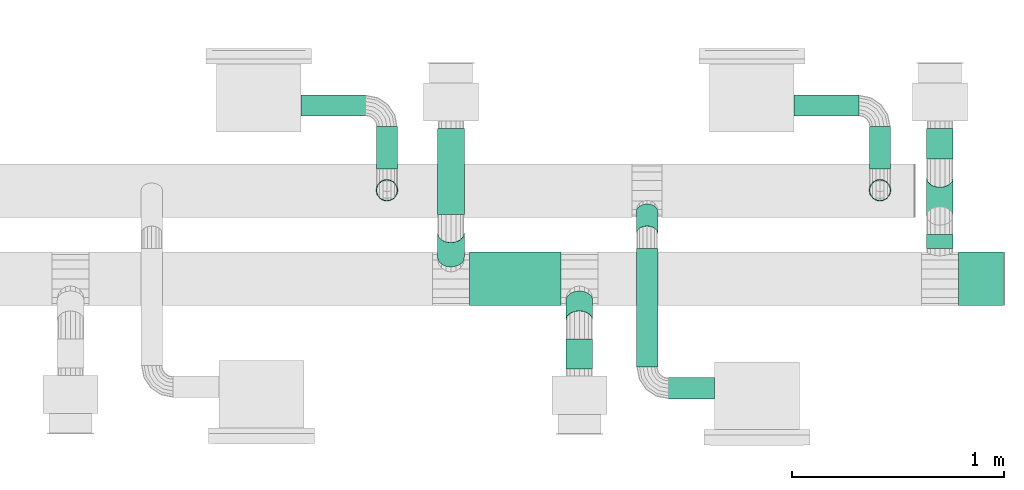
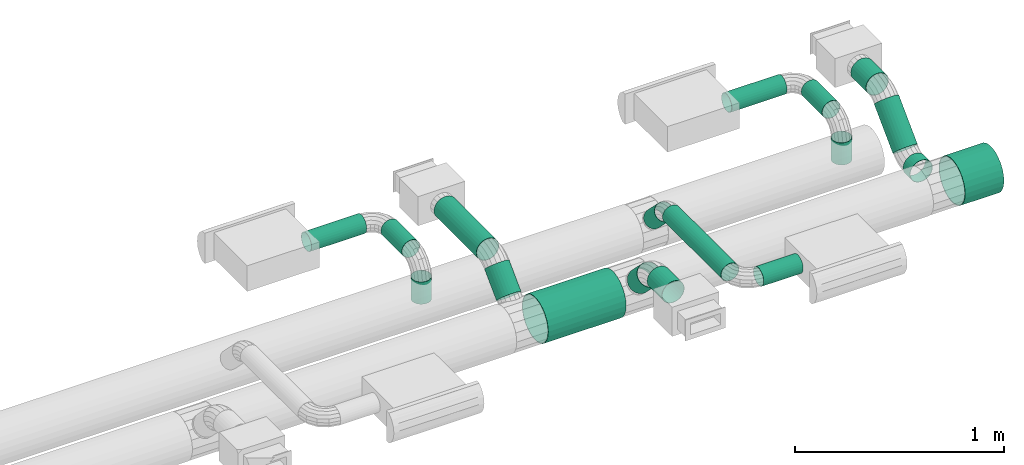
# One storey, part 3 of 11: 18 flow segments.
"""IFC2X3 building model written with IfcOpenShell, lengths in millimetres."""

from ifc_helpers import new_model, si_unit, derived_unit, frame, origin_with_axes, origin_2d_with_axis, place, context, project, spatial, hollow_circle, extrude, source, transform, mapped, type_object, element, save


model = new_model("IFC2X3")

# Units and contexts
context_of_model = context(None, 3, precision=1e-05, world=origin_with_axes())
ifc_project = project(units=[si_unit("LENGTHUNIT", "METRE", prefix="MILLI"), si_unit("AREAUNIT", "SQUARE_METRE"), si_unit("VOLUMEUNIT", "CUBIC_METRE"), si_unit("PLANEANGLEUNIT", "RADIAN"), si_unit("TIMEUNIT", "SECOND"), si_unit("POWERUNIT", "WATT"), si_unit("THERMODYNAMICTEMPERATUREUNIT", "DEGREE_CELSIUS"), derived_unit("VOLUMETRICFLOWRATEUNIT", [(si_unit("VOLUMEUNIT", "CUBIC_METRE"), 1), (si_unit("TIMEUNIT", "SECOND"), -1)])], contexts=[context_of_model])

# Site, building, storey
site_placement = place(None, origin_with_axes())
site = spatial("IfcSite", under=ifc_project, at=site_placement, CompositionType="ELEMENT")
building_placement = place(site_placement, origin_with_axes())
building = spatial("IfcBuilding", under=site, at=building_placement, CompositionType="ELEMENT")
storey_placement = place(building_placement, frame((0.0, 0.0, 3800.0), z_axis=(0.0, 0.0, 1.0), x_axis=(1.0, 0.0, 0.0)))
storey = spatial("IfcBuildingStorey", under=building, at=storey_placement, Name="First floor", CompositionType="ELEMENT")

# Flow segments
duct_segment_type_1 = type_object("IfcDuctSegmentType", PredefinedType="RIGIDSEGMENT")
shared_shape_1 = source(origin_with_axes(), context_of_model, "Body", "SweptSolid", [
    extrude(hollow_circle(Radius=63.0, WallThickness=2.0, at=origin_2d_with_axis()), frame((0.0, 0.0, 0.0), z_axis=(1.0, 0.0, 0.0), x_axis=(0.0, 1.0, 0.0)), (0.0, 0.0, 1.0), 306.0),
])
flow_segment_1_placement = place(storey_placement, frame((12260.89272, 4463.3661, 2566.12943), z_axis=(0.0, -0.707107, 0.707107), x_axis=(0.0, -0.707107, -0.707107)))
element("IfcFlowSegment", 1, at=flow_segment_1_placement, inside=storey, type_object=duct_segment_type_1, context=context_of_model, shape_type="MappedRepresentation", body=[
    mapped(shared_shape_1, transform((0.0, 0.0, 0.0), scale=0.529696, scale2=1.0, scale3=1.0, uniform=False)),
])
duct_segment_type_2 = type_object("IfcDuctSegmentType", PredefinedType="RIGIDSEGMENT")
shared_shape_2 = source(origin_with_axes(), context_of_model, "Body", "SweptSolid", [
    extrude(hollow_circle(Radius=63.0, WallThickness=2.0, at=origin_2d_with_axis()), frame((0.0, 0.0, 0.0), z_axis=(1.0, 0.0, 0.0), x_axis=(0.0, 1.0, 0.0)), (0.0, 0.0, 1.0), 306.0),
])
flow_segment_2_placement = place(storey_placement, frame((12260.89272, 4957.70026, 2602.74108), z_axis=(0.0, 0.0, 1.0), x_axis=(0.0, -1.0, 0.0)))
element("IfcFlowSegment", 2, at=flow_segment_2_placement, inside=storey, type_object=duct_segment_type_2, context=context_of_model, shape_type="MappedRepresentation", body=[
    mapped(shared_shape_2, transform((0.0, 0.0, 0.0), scale=1.328126, scale2=1.0, scale3=1.0, uniform=False)),
])
duct_segment_type_3 = type_object("IfcDuctSegmentType", PredefinedType="RIGIDSEGMENT")
shared_shape_3 = source(origin_with_axes(), context_of_model, "Body", "SweptSolid", [
    extrude(hollow_circle(Radius=63.0, WallThickness=2.0, at=origin_2d_with_axis()), frame((0.0, 0.0, 0.0), z_axis=(1.0, 0.0, 0.0), x_axis=(0.0, 1.0, 0.0)), (0.0, 0.0, 1.0), 306.0),
])
flow_segment_3_placement = place(storey_placement, frame((14567.60117, 4456.19623, 2350.0), z_axis=(0.0, 0.0, 1.0), x_axis=(0.0, -1.0, 0.0)))
element("IfcFlowSegment", 3, at=flow_segment_3_placement, inside=storey, type_object=duct_segment_type_3, context=context_of_model, shape_type="MappedRepresentation", body=[
    mapped(shared_shape_3, transform((0.0, 0.0, 0.0), scale=0.213345, scale2=1.0, scale3=1.0, uniform=False)),
])
duct_segment_type_4 = type_object("IfcDuctSegmentType", PredefinedType="RIGIDSEGMENT")
shared_shape_4 = source(origin_with_axes(), context_of_model, "Body", "SweptSolid", [
    extrude(hollow_circle(Radius=63.0, WallThickness=2.0, at=origin_2d_with_axis()), frame((0.0, 0.0, 0.0), z_axis=(1.0, 0.0, 0.0), x_axis=(0.0, 1.0, 0.0)), (0.0, 0.0, 1.0), 306.0),
])
flow_segment_4_placement = place(storey_placement, frame((14567.60117, 4724.10236, 2566.12943), z_axis=(0.0, -0.707107, 0.707107), x_axis=(0.0, -0.707107, -0.707107)))
element("IfcFlowSegment", 4, at=flow_segment_4_placement, inside=storey, type_object=duct_segment_type_4, context=context_of_model, shape_type="MappedRepresentation", body=[
    mapped(shared_shape_4, transform((0.0, 0.0, 0.0), scale=0.830603, scale2=1.0, scale3=1.0, uniform=False)),
])
duct_segment_type_5 = type_object("IfcDuctSegmentType", PredefinedType="RIGIDSEGMENT")
shared_shape_5 = source(origin_with_axes(), context_of_model, "Body", "SweptSolid", [
    extrude(hollow_circle(Radius=63.0, WallThickness=2.0, at=origin_2d_with_axis()), frame((0.0, 0.0, 0.0), z_axis=(1.0, 0.0, 0.0), x_axis=(0.0, 1.0, 0.0)), (0.0, 0.0, 1.0), 306.0),
])
flow_segment_5_placement = place(storey_placement, frame((14567.60117, 4957.70026, 2602.74108), z_axis=(0.0, 0.0, 1.0), x_axis=(0.0, -1.0, 0.0)))
element("IfcFlowSegment", 5, at=flow_segment_5_placement, inside=storey, type_object=duct_segment_type_5, context=context_of_model, shape_type="MappedRepresentation", body=[
    mapped(shared_shape_5, transform((0.0, 0.0, 0.0), scale=0.47508, scale2=1.0, scale3=1.0, uniform=False)),
])
duct_segment_type_6 = type_object("IfcDuctSegmentType", PredefinedType="RIGIDSEGMENT")
shared_shape_6 = source(origin_with_axes(), context_of_model, "Body", "SweptSolid", [
    extrude(hollow_circle(Radius=63.0, WallThickness=2.0, at=origin_2d_with_axis()), frame((0.0, 0.0, 0.0), z_axis=(1.0, 0.0, 0.0), x_axis=(0.0, 1.0, 0.0)), (0.0, 0.0, 1.0), 306.0),
])
flow_segment_6_placement = place(storey_placement, frame((12779.24589, 4247.23667, 2350.0), z_axis=(0.0, 0.0, 1.0), x_axis=(-1.0, 0.0, 0.0)))
element("IfcFlowSegment", 6, at=flow_segment_6_placement, inside=storey, type_object=duct_segment_type_6, context=context_of_model, shape_type="MappedRepresentation", body=[
    mapped(shared_shape_6, transform((0.0, 0.0, 0.0), scale=1.409615, scale2=2.0, scale3=2.0, uniform=False)),
])
duct_segment_type_7 = type_object("IfcDuctSegmentType", PredefinedType="RIGIDSEGMENT")
shared_shape_7 = source(origin_with_axes(), context_of_model, "Body", "SweptSolid", [
    extrude(hollow_circle(Radius=63.0, WallThickness=2.0, at=origin_2d_with_axis()), frame((0.0, 0.0, 0.0), z_axis=(1.0, 0.0, 0.0), x_axis=(0.0, 1.0, 0.0)), (0.0, 0.0, 1.0), 306.0),
])
flow_segment_7_placement = place(storey_placement, frame((14284.99084, 4665.58509, 2482.0), z_axis=(1.0, 0.0, 0.0), x_axis=(0.0, 0.0, -1.0)))
element("IfcFlowSegment", 7, at=flow_segment_7_placement, inside=storey, type_object=duct_segment_type_7, context=context_of_model, shape_type="MappedRepresentation", body=[
    mapped(shared_shape_7, transform((0.0, 0.0, 0.0), scale=0.425319, scale2=0.8, scale3=0.8, uniform=False)),
])
duct_segment_type_8 = type_object("IfcDuctSegmentType", PredefinedType="RIGIDSEGMENT")
shared_shape_8 = source(origin_with_axes(), context_of_model, "Body", "SweptSolid", [
    extrude(hollow_circle(Radius=63.0, WallThickness=2.0, at=origin_2d_with_axis()), frame((0.0, 0.0, 0.0), z_axis=(1.0, 0.0, 0.0), x_axis=(0.0, 1.0, 0.0)), (0.0, 0.0, 1.0), 306.0),
])
flow_segment_8_placement = place(storey_placement, frame((14284.99084, 4965.32653, 2582.0), z_axis=(0.0, 0.0, 1.0), x_axis=(0.0, -1.0, 0.0)))
element("IfcFlowSegment", 8, at=flow_segment_8_placement, inside=storey, type_object=duct_segment_type_8, context=context_of_model, shape_type="MappedRepresentation", body=[
    mapped(shared_shape_8, transform((0.0, 0.0, 0.0), scale=0.65349, scale2=0.8, scale3=0.8, uniform=False)),
])
duct_segment_type_9 = type_object("IfcDuctSegmentType", PredefinedType="RIGIDSEGMENT")
shared_shape_9 = source(origin_with_axes(), context_of_model, "Body", "SweptSolid", [
    extrude(hollow_circle(Radius=63.0, WallThickness=2.0, at=origin_2d_with_axis()), frame((0.0, 0.0, 0.0), z_axis=(1.0, 0.0, 0.0), x_axis=(0.0, 1.0, 0.0)), (0.0, 0.0, 1.0), 306.0),
])
flow_segment_9_placement = place(storey_placement, frame((13880.22257, 5065.32653, 2582.0), z_axis=(0.0, 0.0, 1.0), x_axis=(1.0, 0.0, 0.0)))
element("IfcFlowSegment", 9, at=flow_segment_9_placement, inside=storey, type_object=duct_segment_type_9, context=context_of_model, shape_type="MappedRepresentation", body=[
    mapped(shared_shape_9, transform((0.0, 0.0, 0.0), scale=0.997105, scale2=0.8, scale3=0.8, uniform=False)),
])
shared_shape_10 = source(origin_with_axes(), context_of_model, "Body", "SweptSolid", [
    extrude(hollow_circle(Radius=63.0, WallThickness=2.0, at=origin_2d_with_axis()), frame((0.0, 0.0, 0.0), z_axis=(1.0, 0.0, 0.0), x_axis=(0.0, 1.0, 0.0)), (0.0, 0.0, 1.0), 306.0),
])
flow_segment_10_placement = place(storey_placement, frame((11958.99327, 4665.58509, 2482.0), z_axis=(1.0, 0.0, 0.0), x_axis=(0.0, 0.0, -1.0)))
element("IfcFlowSegment", 10, at=flow_segment_10_placement, inside=storey, type_object=duct_segment_type_7, context=context_of_model, shape_type="MappedRepresentation", body=[
    mapped(shared_shape_10, transform((0.0, 0.0, 0.0), scale=0.425319, scale2=0.8, scale3=0.8, uniform=False)),
])
shared_shape_11 = source(origin_with_axes(), context_of_model, "Body", "SweptSolid", [
    extrude(hollow_circle(Radius=63.0, WallThickness=2.0, at=origin_2d_with_axis()), frame((0.0, 0.0, 0.0), z_axis=(1.0, 0.0, 0.0), x_axis=(0.0, 1.0, 0.0)), (0.0, 0.0, 1.0), 306.0),
])
flow_segment_11_placement = place(storey_placement, frame((11958.99327, 4965.32653, 2582.0), z_axis=(0.0, 0.0, 1.0), x_axis=(0.0, -1.0, 0.0)))
element("IfcFlowSegment", 11, at=flow_segment_11_placement, inside=storey, type_object=duct_segment_type_8, context=context_of_model, shape_type="MappedRepresentation", body=[
    mapped(shared_shape_11, transform((0.0, 0.0, 0.0), scale=0.65349, scale2=0.8, scale3=0.8, uniform=False)),
])
shared_shape_12 = source(origin_with_axes(), context_of_model, "Body", "SweptSolid", [
    extrude(hollow_circle(Radius=63.0, WallThickness=2.0, at=origin_2d_with_axis()), frame((0.0, 0.0, 0.0), z_axis=(1.0, 0.0, 0.0), x_axis=(0.0, 1.0, 0.0)), (0.0, 0.0, 1.0), 306.0),
])
flow_segment_12_placement = place(storey_placement, frame((11554.225, 5065.32653, 2582.0), z_axis=(0.0, 0.0, 1.0), x_axis=(1.0, 0.0, 0.0)))
element("IfcFlowSegment", 12, at=flow_segment_12_placement, inside=storey, type_object=duct_segment_type_9, context=context_of_model, shape_type="MappedRepresentation", body=[
    mapped(shared_shape_12, transform((0.0, 0.0, 0.0), scale=0.997105, scale2=0.8, scale3=0.8, uniform=False)),
])
duct_segment_type_10 = type_object("IfcDuctSegmentType", PredefinedType="RIGIDSEGMENT")
shared_shape_13 = source(origin_with_axes(), context_of_model, "Body", "SweptSolid", [
    extrude(hollow_circle(Radius=63.0, WallThickness=2.0, at=origin_2d_with_axis()), frame((0.0, 0.0, 0.0), z_axis=(1.0, 0.0, 0.0), x_axis=(0.0, 1.0, 0.0)), (0.0, 0.0, 1.0), 306.0),
])
flow_segment_13_placement = place(storey_placement, frame((14870.02779, 4247.23667, 2350.0), z_axis=(0.0, 0.0, 1.0), x_axis=(-1.0, 0.0, 0.0)))
element("IfcFlowSegment", 13, at=flow_segment_13_placement, inside=storey, type_object=duct_segment_type_10, context=context_of_model, shape_type="MappedRepresentation", body=[
    mapped(shared_shape_13, transform((0.0, 0.0, 0.0), scale=0.703172, scale2=2.0, scale3=2.0, uniform=False)),
])
duct_segment_type_11 = type_object("IfcDuctSegmentType", PredefinedType="RIGIDSEGMENT")
shared_shape_14 = source(origin_with_axes(), context_of_model, "Body", "SweptSolid", [
    extrude(hollow_circle(Radius=63.0, WallThickness=2.0, at=origin_2d_with_axis()), frame((0.0, 0.0, 0.0), z_axis=(1.0, 0.0, 0.0), x_axis=(0.0, 1.0, 0.0)), (0.0, 0.0, 1.0), 306.0),
])
flow_segment_14_placement = place(storey_placement, frame((12866.74589, 4051.84832, 2545.38835), z_axis=(0.0, 0.707107, 0.707107), x_axis=(0.0, 0.707107, -0.707107)))
element("IfcFlowSegment", 14, at=flow_segment_14_placement, inside=storey, type_object=duct_segment_type_11, context=context_of_model, shape_type="MappedRepresentation", body=[
    mapped(shared_shape_14, transform((0.0, 0.0, 0.0), scale=0.43373, scale2=1.0, scale3=1.0, uniform=False)),
])
duct_segment_type_12 = type_object("IfcDuctSegmentType", PredefinedType="RIGIDSEGMENT")
shared_shape_15 = source(origin_with_axes(), context_of_model, "Body", "SweptSolid", [
    extrude(hollow_circle(Radius=63.0, WallThickness=2.0, at=origin_2d_with_axis()), frame((0.0, 0.0, 0.0), z_axis=(1.0, 0.0, 0.0), x_axis=(0.0, 1.0, 0.0)), (0.0, 0.0, 1.0), 306.0),
])
flow_segment_15_placement = place(storey_placement, frame((12866.74589, 3823.51972, 2582.0), z_axis=(0.0, 0.0, 1.0), x_axis=(0.0, 1.0, 0.0)))
element("IfcFlowSegment", 15, at=flow_segment_15_placement, inside=storey, type_object=duct_segment_type_12, context=context_of_model, shape_type="MappedRepresentation", body=[
    mapped(shared_shape_15, transform((0.0, 0.0, 0.0), scale=0.45784, scale2=1.0, scale3=1.0, uniform=False)),
])
duct_segment_type_13 = type_object("IfcDuctSegmentType", PredefinedType="RIGIDSEGMENT")
shared_shape_16 = source(origin_with_axes(), context_of_model, "Body", "SweptSolid", [
    extrude(hollow_circle(Radius=63.0, WallThickness=2.0, at=origin_2d_with_axis()), frame((0.0, 0.0, 0.0), z_axis=(1.0, 0.0, 0.0), x_axis=(0.0, 1.0, 0.0)), (0.0, 0.0, 1.0), 306.0),
])
flow_segment_16_placement = place(storey_placement, frame((13186.23995, 4461.15678, 2552.71068), z_axis=(0.0, 0.707107, 0.707107), x_axis=(0.0, 0.707107, -0.707107)))
element("IfcFlowSegment", 16, at=flow_segment_16_placement, inside=storey, type_object=duct_segment_type_13, context=context_of_model, shape_type="MappedRepresentation", body=[
    mapped(shared_shape_16, transform((0.0, 0.0, 0.0), scale=0.479878, scale2=0.8, scale3=0.8, uniform=False)),
])
duct_segment_type_14 = type_object("IfcDuctSegmentType", PredefinedType="RIGIDSEGMENT")
shared_shape_17 = source(origin_with_axes(), context_of_model, "Body", "SweptSolid", [
    extrude(hollow_circle(Radius=63.0, WallThickness=2.0, at=origin_2d_with_axis()), frame((0.0, 0.0, 0.0), z_axis=(1.0, 0.0, 0.0), x_axis=(0.0, 1.0, 0.0)), (0.0, 0.0, 1.0), 306.0),
])
flow_segment_17_placement = place(storey_placement, frame((13186.23995, 3831.07289, 2582.0), z_axis=(0.0, 0.0, 1.0), x_axis=(0.0, 1.0, 0.0)))
element("IfcFlowSegment", 17, at=flow_segment_17_placement, inside=storey, type_object=duct_segment_type_14, context=context_of_model, shape_type="MappedRepresentation", body=[
    mapped(shared_shape_17, transform((0.0, 0.0, 0.0), scale=1.830091, scale2=0.8, scale3=0.8, uniform=False)),
])
duct_segment_type_15 = type_object("IfcDuctSegmentType", PredefinedType="RIGIDSEGMENT")
shared_shape_18 = source(origin_with_axes(), context_of_model, "Body", "SweptSolid", [
    extrude(hollow_circle(Radius=63.0, WallThickness=2.0, at=origin_2d_with_axis()), frame((0.0, 0.0, 0.0), z_axis=(1.0, 0.0, 0.0), x_axis=(0.0, 1.0, 0.0)), (0.0, 0.0, 1.0), 306.0),
])
flow_segment_18_placement = place(storey_placement, frame((13504.51284, 3731.07289, 2582.0), z_axis=(0.0, 0.0, 1.0), x_axis=(-1.0, 0.0, 0.0)))
element("IfcFlowSegment", 18, at=flow_segment_18_placement, inside=storey, type_object=duct_segment_type_15, context=context_of_model, shape_type="MappedRepresentation", body=[
    mapped(shared_shape_18, transform((0.0, 0.0, 0.0), scale=0.714119, scale2=0.8, scale3=0.8, uniform=False)),
])

save(model, "model.ifc")
